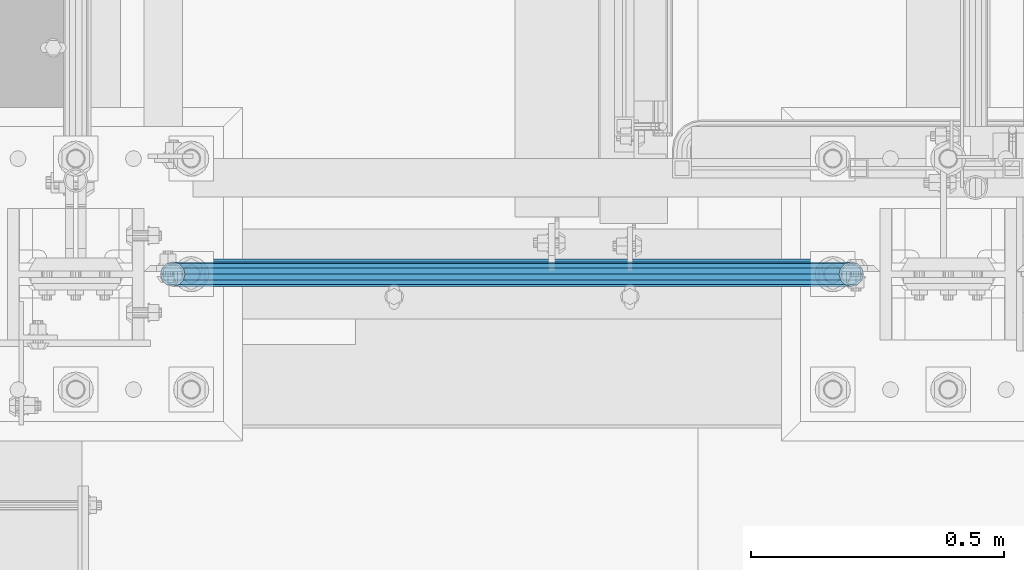
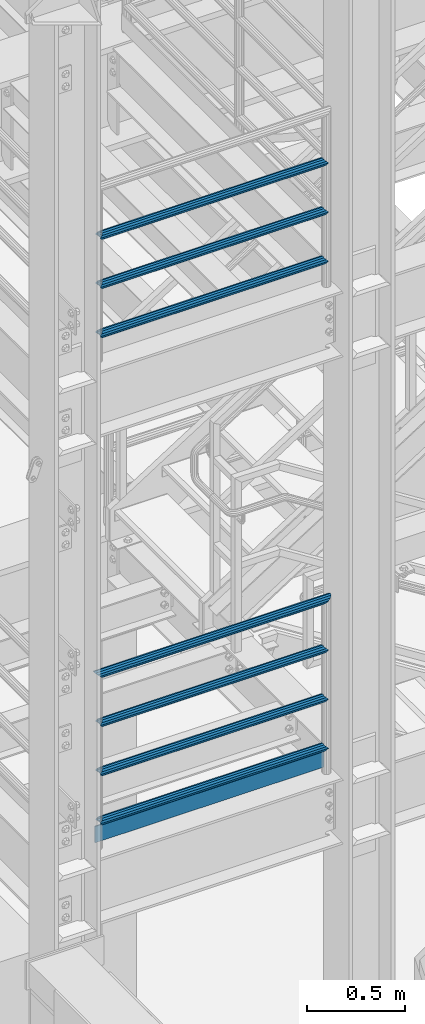
# One storey, part 930 of 1876: 8 beams, 2 elements without a shape of their own.
"""IFC2X3 building model written with IfcOpenShell, lengths in millimetres."""

from ifc_helpers import new_model, si_unit, frame, origin_with_axes, place, context, subcontext, project, spatial, faceted_brep, material, type_object, element, aggregate, save


model = new_model("IFC2X3")

# Units and contexts
model_context = context("Model", 3, precision=1e-05, world=origin_with_axes())
body_context = subcontext(model_context, "Body", "Model", "MODEL_VIEW")
ifc_project = project(units=[si_unit("LENGTHUNIT", "METRE", prefix="MILLI"), si_unit("AREAUNIT", "SQUARE_METRE"), si_unit("VOLUMEUNIT", "CUBIC_METRE"), si_unit("MASSUNIT", "GRAM", prefix="KILO"), si_unit("TIMEUNIT", "SECOND"), si_unit("PLANEANGLEUNIT", "RADIAN"), si_unit("SOLIDANGLEUNIT", "STERADIAN"), si_unit("THERMODYNAMICTEMPERATUREUNIT", "DEGREE_CELSIUS"), si_unit("LUMINOUSINTENSITYUNIT", "LUMEN")], contexts=[model_context])

# Site, building, storey
site_placement = place(None, origin_with_axes())
site = spatial("IfcSite", under=ifc_project, at=site_placement, CompositionType="ELEMENT")
building_placement = place(site_placement, origin_with_axes())
building = spatial("IfcBuilding", under=site, at=building_placement, Name="Undefined", CompositionType="ELEMENT")
storey_placement = place(building_placement, origin_with_axes())
storey = spatial("IfcBuildingStorey", under=building, at=storey_placement, Name="Undefined", CompositionType="ELEMENT", Elevation=0.0)

# Assembly, beams
assembly_1_placement = place(storey_placement, origin_with_axes())
assembly_1 = element("IfcElementAssembly", 1, at=assembly_1_placement, inside=storey, Name="RAIL", AssemblyPlace="NOTDEFINED", PredefinedType="RIGID_FRAME")
ifc_material_1 = material()
beam_type_1 = type_object("IfcBeamType", Name="PIPE1-1/2SCH40", PredefinedType="NOTDEFINED")
beam_1_placement = place(assembly_1_placement, frame((192.0875, -7112.0, 5292.72499999999), z_axis=(0.0, 0.0, 1.0), x_axis=(1.0, 0.0, 0.0)))
beam_1 = element("IfcBeam", 2, at=beam_1_placement, type_object=beam_type_1, material=ifc_material_1, Name="RAIL", ObjectType="PIPE1-1/2SCH40", context=body_context, shape_type="Brep", body=[
    faceted_brep([(1322.12780700668, -12.0649999999996, 20.8971929933186), (1322.12780700668, -12.0649999999996, 15.8661214311805), (1321.63437856882, -10.2235000000001, 17.7076214311801), (1318.895, 0.0, 20.4470000000001), (1318.895, 0.0, 24.1300000000001), (1321.63437856882, 10.2235000000001, 17.7076214311801), (1322.12780700668, 12.0649999999996, 15.8661214311805), (1322.12780700668, 12.0649999999996, 20.8971929933186), (1343.025, 24.1300000000001, 0.0), (1330.96, 20.8971929933186, 12.0649999999996), (1330.96, 20.8971929933186, -12.0649999999996), (1327.77042843786, 17.7076214311801, 10.2235000000001), (1330.50980700668, 20.4470000000001, 0.0), (1327.77042843786, 17.7076214311801, -10.2235000000001), (1322.12780700668, 12.0649999999996, -15.8661214311805), (1322.12780700668, 12.0649999999996, -20.8971929933186), (1321.63437856882, 10.2235000000001, -17.7076214311801), (1318.895, 0.0, -20.4470000000001), (1318.895, 0.0, -24.1300000000001), (1322.12780700668, -12.0649999999996, -15.8661214311805), (1322.12780700668, -12.0649999999996, -20.8971929933186), (1321.63437856882, -10.2235000000001, -17.7076214311801), (1343.025, -24.1300000000001, 0.0), (1330.96, -20.8971929933186, -12.0649999999996), (1330.96, -20.8971929933186, 12.0649999999996), (1327.77042843786, -17.7076214311801, -10.2235000000001), (1330.50980700668, -20.4470000000001, 0.0), (1327.77042843786, -17.7076214311801, 10.2235000000001), (12.0650000000064, -20.8971929933177, -12.0649999999987), (20.8971929933249, -12.0650000000005, -20.8971929933177), (0.0, 24.1299999999992, 0.0), (12.0650000000064, 20.8971929933177, -12.0649999999987), (12.0650000000064, 20.8971929933177, 12.0649999999987), (20.8971929933249, 12.0650000000005, 20.8971929933177), (24.1300000000064, 0.0, 24.130000000001), (20.8971929933249, 12.0650000000005, -20.8971929933177), (24.1300000000063, 0.0, -24.130000000001), (24.1300000000063, 0.0, -20.4470000000001), (20.8971929933249, -12.0650000000005, -15.8661214311796), (21.3906214311868, -10.2235000000001, -17.7076214311819), (21.3906214311868, 10.2235000000001, -17.7076214311819), (20.8971929933249, 12.0650000000005, -15.8661214311796), (15.2545715621445, 17.7076214311801, -10.2235000000001), (12.5151929933249, 20.4470000000001, 0.0), (15.2545715621445, 17.7076214311801, 10.2235000000001), (20.8971929933249, 12.0650000000005, 15.8661214311796), (21.3906214311868, 10.2235000000001, 17.7076214311819), (24.1300000000064, 0.0, 20.4470000000001), (21.3906214311868, -10.2235000000001, 17.7076214311819), (20.8971929933249, -12.0650000000005, 15.8661214311796), (20.8971929933249, -12.0650000000005, 20.8971929933177), (12.0650000000064, -20.8971929933177, 12.0649999999987), (0.0, -24.1299999999992, 0.0), (15.2545715621445, -17.7076214311801, 10.2235000000001), (12.5151929933249, -20.4470000000001, 0.0), (15.2545715621445, -17.7076214311801, -10.2235000000001)], [[[0, 1, 2, 3, 4]], [[4, 3, 5, 6, 7]], [[8, 9, 10]], [[7, 6, 11, 12, 13, 14, 15, 10, 9]], [[16, 17, 18, 15, 14]], [[19, 20, 18, 17, 21]], [[22, 23, 24]], [[24, 23, 20, 19, 25, 26, 27, 1, 0]], [[28, 29, 20, 23]], [[30, 31, 32]], [[33, 34, 4, 7]], [[32, 33, 7, 9]], [[30, 32, 9, 8]], [[31, 30, 8, 10]], [[35, 31, 10, 15]], [[36, 35, 15, 18]], [[29, 36, 18, 20]], [[37, 36, 29, 38, 39]], [[40, 41, 35, 36, 37]], [[32, 31, 35, 41, 42, 43, 44, 45, 33]], [[33, 45, 46, 47, 34]], [[34, 47, 48, 49, 50]], [[34, 50, 0, 4]], [[50, 51, 24, 0]], [[51, 52, 22, 24]], [[52, 28, 23, 22]], [[51, 28, 52]], [[50, 49, 53, 54, 55, 38, 29, 28, 51]], [[55, 54, 26, 25]], [[21, 39, 38, 55, 25, 19]], [[37, 39, 21, 17]], [[40, 37, 17, 16]], [[42, 41, 40, 16, 14, 13]], [[43, 42, 13, 12]], [[44, 43, 12, 11]], [[5, 46, 45, 44, 11, 6]], [[47, 46, 5, 3]], [[48, 47, 3, 2]], [[53, 49, 48, 2, 1, 27]], [[54, 53, 27, 26]]]),
])
beam_2_placement = place(assembly_1_placement, frame((1535.1125, -7112.0, 5597.52499999999), z_axis=(0.0, 0.0, -1.0), x_axis=(-1.0, 0.0, 0.0)))
beam_2 = element("IfcBeam", 3, at=beam_2_placement, type_object=beam_type_1, material=ifc_material_1, Name="RAIL", ObjectType="PIPE1-1/2SCH40", context=body_context, shape_type="Brep", body=[
    faceted_brep([(0.0, 24.1299999999992, 0.0), (12.0650000000064, 20.8971929933177, -12.0649999999987), (12.0650000000064, 20.8971929933177, 12.0649999999987), (12.0650000000064, -20.8971929933177, 12.0649999999987), (12.0650000000064, -20.8971929933177, -12.0649999999987), (0.0, -24.1299999999992, 0.0), (20.8971929933249, -12.0650000000005, 20.8971929933177), (20.8971929933249, -12.0650000000005, 15.8661214311796), (15.2545715621445, -17.7076214311801, 10.2235000000001), (12.5151929933249, -20.4470000000001, 0.0), (15.2545715621445, -17.7076214311801, -10.2235000000001), (20.8971929933249, -12.0650000000005, -15.8661214311796), (20.8971929933249, -12.0650000000005, -20.8971929933177), (24.1300000000063, 0.0, -20.4470000000001), (24.1300000000063, 0.0, -24.130000000001), (21.3906214311868, -10.2235000000001, -17.7076214311819), (21.3906214311868, 10.2235000000001, -17.7076214311819), (20.8971929933249, 12.0650000000005, -15.8661214311796), (20.8971929933249, 12.0650000000005, -20.8971929933177), (15.2545715621445, 17.7076214311801, -10.2235000000001), (12.5151929933249, 20.4470000000001, 0.0), (15.2545715621445, 17.7076214311801, 10.2235000000001), (20.8971929933249, 12.0650000000005, 15.8661214311796), (20.8971929933249, 12.0650000000005, 20.8971929933177), (21.3906214311868, 10.2235000000001, 17.7076214311819), (24.1300000000064, 0.0, 20.4470000000001), (24.1300000000064, 0.0, 24.130000000001), (21.3906214311868, -10.2235000000001, 17.7076214311819), (1343.025, 24.1300000000001, 0.0), (1330.96, 20.8971929933186, -12.0649999999996), (1322.12780700668, 12.0649999999996, -20.8971929933186), (1343.025, -24.1300000000001, 0.0), (1330.96, -20.8971929933186, -12.0649999999996), (1330.96, -20.8971929933186, 12.0649999999996), (1322.12780700668, -12.0649999999996, 20.8971929933186), (1322.12780700668, -12.0649999999996, -20.8971929933186), (1318.895, 0.0, -24.1300000000001), (1321.63437856882, 10.2235000000001, -17.7076214311801), (1318.895, 0.0, -20.4470000000001), (1322.12780700668, 12.0649999999996, -15.8661214311805), (1322.12780700668, -12.0649999999996, -15.8661214311805), (1321.63437856882, -10.2235000000001, -17.7076214311801), (1327.77042843786, -17.7076214311801, -10.2235000000001), (1330.50980700668, -20.4470000000001, 0.0), (1327.77042843786, -17.7076214311801, 10.2235000000001), (1322.12780700668, -12.0649999999996, 15.8661214311805), (1321.63437856882, -10.2235000000001, 17.7076214311801), (1318.895, 0.0, 20.4470000000001), (1318.895, 0.0, 24.1300000000001), (1322.12780700668, 12.0649999999996, 20.8971929933186), (1330.96, 20.8971929933186, 12.0649999999996), (1322.12780700668, 12.0649999999996, 15.8661214311805), (1327.77042843786, 17.7076214311801, 10.2235000000001), (1330.50980700668, 20.4470000000001, 0.0), (1327.77042843786, 17.7076214311801, -10.2235000000001), (1321.63437856882, 10.2235000000001, 17.7076214311801)], [[[0, 1, 2]], [[3, 4, 5]], [[6, 7, 8, 9, 10, 11, 12, 4, 3]], [[13, 14, 12, 11, 15]], [[16, 17, 18, 14, 13]], [[2, 1, 18, 17, 19, 20, 21, 22, 23]], [[23, 22, 24, 25, 26]], [[26, 25, 27, 7, 6]], [[1, 0, 28, 29]], [[18, 1, 29, 30]], [[31, 32, 33]], [[6, 3, 33, 34]], [[3, 5, 31, 33]], [[5, 4, 32, 31]], [[4, 12, 35, 32]], [[12, 14, 36, 35]], [[14, 18, 30, 36]], [[37, 38, 36, 30, 39]], [[40, 35, 36, 38, 41]], [[33, 32, 35, 40, 42, 43, 44, 45, 34]], [[34, 45, 46, 47, 48]], [[26, 6, 34, 48]], [[2, 23, 49, 50]], [[23, 26, 48, 49]], [[0, 2, 50, 28]], [[28, 50, 29]], [[49, 51, 52, 53, 54, 39, 30, 29, 50]], [[48, 47, 55, 51, 49]], [[25, 24, 55, 47]], [[55, 24, 22, 21, 52, 51]], [[21, 20, 53, 52]], [[20, 19, 54, 53]], [[19, 17, 16, 37, 39, 54]], [[16, 13, 38, 37]], [[13, 15, 41, 38]], [[41, 15, 11, 10, 42, 40]], [[10, 9, 43, 42]], [[9, 8, 44, 43]], [[8, 7, 27, 46, 45, 44]], [[27, 25, 47, 46]]]),
])
beam_3_placement = place(assembly_1_placement, frame((1535.1125, -7112.0, 5902.325), z_axis=(0.0, 0.0, -1.0), x_axis=(-1.0, 0.0, 0.0)))
beam_3 = element("IfcBeam", 4, at=beam_3_placement, type_object=beam_type_1, material=ifc_material_1, Name="RAIL", ObjectType="PIPE1-1/2SCH40", context=body_context, shape_type="Brep", body=[
    faceted_brep([(0.0, 24.1299999999992, 0.0), (12.0650000000064, 20.8971929933177, -12.0649999999987), (12.0650000000064, 20.8971929933177, 12.0649999999987), (12.0650000000064, -20.8971929933177, 12.0649999999987), (12.0650000000064, -20.8971929933177, -12.0649999999987), (0.0, -24.1299999999992, 0.0), (20.8971929933249, -12.0650000000005, 20.8971929933177), (20.8971929933249, -12.0650000000005, 15.8661214311796), (15.2545715621445, -17.7076214311801, 10.2235000000001), (12.5151929933249, -20.4470000000001, 0.0), (15.2545715621445, -17.7076214311801, -10.2235000000001), (20.8971929933249, -12.0650000000005, -15.8661214311796), (20.8971929933249, -12.0650000000005, -20.8971929933177), (24.1300000000063, 0.0, -20.4470000000001), (24.1300000000063, 0.0, -24.130000000001), (21.3906214311868, -10.2235000000001, -17.7076214311819), (21.3906214311868, 10.2235000000001, -17.7076214311819), (20.8971929933249, 12.0650000000005, -15.8661214311796), (20.8971929933249, 12.0650000000005, -20.8971929933177), (15.2545715621445, 17.7076214311801, -10.2235000000001), (12.5151929933249, 20.4470000000001, 0.0), (15.2545715621445, 17.7076214311801, 10.2235000000001), (20.8971929933249, 12.0650000000005, 15.8661214311796), (20.8971929933249, 12.0650000000005, 20.8971929933177), (21.3906214311868, 10.2235000000001, 17.7076214311819), (24.1300000000064, 0.0, 20.4470000000001), (24.1300000000064, 0.0, 24.130000000001), (21.3906214311868, -10.2235000000001, 17.7076214311819), (1343.025, 24.1300000000001, 0.0), (1330.96, 20.8971929933186, -12.0649999999996), (1322.12780700668, 12.0649999999996, -20.8971929933186), (1343.025, -24.1300000000001, 0.0), (1330.96, -20.8971929933186, -12.0649999999996), (1330.96, -20.8971929933186, 12.0649999999996), (1322.12780700668, -12.0649999999996, 20.8971929933186), (1322.12780700668, -12.0649999999996, -20.8971929933186), (1318.895, 0.0, -24.1300000000001), (1321.63437856882, 10.2235000000001, -17.7076214311801), (1318.895, 0.0, -20.4470000000001), (1322.12780700668, 12.0649999999996, -15.8661214311805), (1322.12780700668, -12.0649999999996, -15.8661214311805), (1321.63437856882, -10.2235000000001, -17.7076214311801), (1327.77042843786, -17.7076214311801, -10.2235000000001), (1330.50980700668, -20.4470000000001, 0.0), (1327.77042843786, -17.7076214311801, 10.2235000000001), (1322.12780700668, -12.0649999999996, 15.8661214311805), (1321.63437856882, -10.2235000000001, 17.7076214311801), (1318.895, 0.0, 20.4470000000001), (1318.895, 0.0, 24.1300000000001), (1322.12780700668, 12.0649999999996, 20.8971929933186), (1330.96, 20.8971929933186, 12.0649999999996), (1322.12780700668, 12.0649999999996, 15.8661214311805), (1327.77042843786, 17.7076214311801, 10.2235000000001), (1330.50980700668, 20.4470000000001, 0.0), (1327.77042843786, 17.7076214311801, -10.2235000000001), (1321.63437856882, 10.2235000000001, 17.7076214311801)], [[[0, 1, 2]], [[3, 4, 5]], [[6, 7, 8, 9, 10, 11, 12, 4, 3]], [[13, 14, 12, 11, 15]], [[16, 17, 18, 14, 13]], [[2, 1, 18, 17, 19, 20, 21, 22, 23]], [[23, 22, 24, 25, 26]], [[26, 25, 27, 7, 6]], [[1, 0, 28, 29]], [[18, 1, 29, 30]], [[31, 32, 33]], [[6, 3, 33, 34]], [[3, 5, 31, 33]], [[5, 4, 32, 31]], [[4, 12, 35, 32]], [[12, 14, 36, 35]], [[14, 18, 30, 36]], [[37, 38, 36, 30, 39]], [[40, 35, 36, 38, 41]], [[33, 32, 35, 40, 42, 43, 44, 45, 34]], [[34, 45, 46, 47, 48]], [[26, 6, 34, 48]], [[2, 23, 49, 50]], [[23, 26, 48, 49]], [[0, 2, 50, 28]], [[28, 50, 29]], [[49, 51, 52, 53, 54, 39, 30, 29, 50]], [[48, 47, 55, 51, 49]], [[25, 24, 55, 47]], [[55, 24, 22, 21, 52, 51]], [[21, 20, 53, 52]], [[20, 19, 54, 53]], [[19, 17, 16, 37, 39, 54]], [[16, 13, 38, 37]], [[13, 15, 41, 38]], [[41, 15, 11, 10, 42, 40]], [[10, 9, 43, 42]], [[9, 8, 44, 43]], [[8, 7, 27, 46, 45, 44]], [[27, 25, 47, 46]]]),
])
beam_4_placement = place(assembly_1_placement, frame((1559.2425, -7112.0, 6207.12499999999), z_axis=(0.0, 0.0, -1.0), x_axis=(-1.0, 0.0, 0.0)))
beam_4 = element("IfcBeam", 5, at=beam_4_placement, type_object=beam_type_1, material=ifc_material_1, Name="RAIL", ObjectType="PIPE1-1/2SCH40", context=body_context, shape_type="Brep", body=[
    faceted_brep([(24.1300000000001, -20.4469999999999, 0.0), (34.3535000000002, -17.7076214311803, 10.2235000000001), (1356.9315, -17.7076214311801, 10.2235000000001), (1367.155, -20.4470000000001, 0.0), (41.8376214311802, -10.2235000000001, 17.7076214311819), (1349.44737856882, -10.2235000000001, 17.7076214311801), (44.5770000000002, 0.0, 20.4470000000001), (1346.708, 0.0, 20.4470000000001), (41.8376214311802, 10.2235000000001, 17.7076214311819), (1349.44737856882, 10.2235000000001, 17.7076214311801), (34.3535000000002, 17.7076214311803, 10.2235000000001), (1356.9315, 17.7076214311801, 10.2235000000001), (24.1300000000001, 20.4469999999999, 0.0), (1367.155, 20.4470000000001, 0.0), (13.9065000000001, 17.7076214311803, -10.2235000000001), (1377.3785, 17.7076214311801, -10.2235000000001), (6.42237856882002, 10.2235000000001, -17.7076214311819), (1384.86262143118, 10.2235000000001, -17.7076214311801), (3.68299999999999, 0.0, -20.4470000000001), (1387.602, 0.0, -20.4470000000001), (6.42237856882002, -10.2235000000001, -17.7076214311819), (1384.86262143118, -10.2235000000001, -17.7076214311801), (13.9065000000001, -17.7076214311803, -10.2235000000001), (1377.3785, -17.7076214311801, -10.2235000000001), (24.1299999999854, -24.1299999999992, 0.0), (12.0650000000064, -20.8971929933177, -12.0649999999987), (1379.22, -20.8971929933186, -12.0649999999996), (1367.155, -24.1300000000001, 0.0), (3.23280700668147, -12.0650000000001, -20.8971929933177), (1388.05219299332, -12.0649999999996, -20.8971929933186), (-1.45519152283669e-11, 0.0, -24.130000000001), (1391.285, 0.0, -24.1300000000001), (3.23280700668147, 12.0650000000001, -20.8971929933177), (1388.05219299332, 12.0649999999996, -20.8971929933186), (12.0650000000064, 20.8971929933177, -12.0649999999987), (1379.22, 20.8971929933186, -12.0649999999996), (24.1300000000047, 24.1299999999992, 0.0), (1367.155, 24.1300000000001, 0.0), (36.1949999999997, 20.8971929933184, 12.0649999999987), (1355.09, 20.8971929933186, 12.0649999999996), (45.0271929933187, 12.0650000000001, 20.8971929933177), (1346.25780700668, 12.0649999999996, 20.8971929933186), (48.2600000000002, 0.0, 24.130000000001), (1343.025, 0.0, 24.1300000000001), (45.0271929933187, -12.0650000000001, 20.8971929933177), (1346.25780700668, -12.0649999999996, 20.8971929933186), (36.1949999999997, -20.8971929933184, 12.0649999999987), (1355.09, -20.8971929933186, 12.0649999999996)], [[[0, 1, 2, 3]], [[1, 4, 5, 2]], [[4, 6, 7, 5]], [[6, 8, 9, 7]], [[8, 10, 11, 9]], [[10, 12, 13, 11]], [[12, 14, 15, 13]], [[14, 16, 17, 15]], [[16, 18, 19, 17]], [[18, 20, 21, 19]], [[20, 22, 23, 21]], [[22, 0, 3, 23]], [[24, 25, 26, 27]], [[25, 28, 29, 26]], [[28, 30, 31, 29]], [[30, 32, 33, 31]], [[32, 34, 35, 33]], [[34, 36, 37, 35]], [[36, 38, 39, 37]], [[38, 40, 41, 39]], [[40, 42, 43, 41]], [[42, 44, 45, 43]], [[44, 46, 47, 45]], [[46, 24, 27, 47]], [[29, 31, 33, 35, 37, 39, 41, 43, 45, 47, 27, 26], [5, 7, 9, 11, 13, 15, 17, 19, 21, 23, 3, 2]], [[46, 44, 42, 40, 38, 36, 34, 32, 30, 28, 25, 24], [22, 20, 18, 16, 14, 12, 10, 8, 6, 4, 1, 0]]]),
])

assembly_2_placement = place(storey_placement, origin_with_axes())
assembly_2 = element("IfcElementAssembly", 6, at=assembly_2_placement, inside=storey, Name="RAIL", AssemblyPlace="NOTDEFINED", PredefinedType="RIGID_FRAME")
beam_5_placement = place(assembly_2_placement, frame((192.0875, -7112.0, 8315.325), z_axis=(0.0, 0.0, 1.0), x_axis=(1.0, 0.0, 0.0)))
beam_5 = element("IfcBeam", 7, at=beam_5_placement, type_object=beam_type_1, material=ifc_material_1, Name="RAIL", ObjectType="PIPE1-1/2SCH40", context=body_context, shape_type="Brep", body=[
    faceted_brep([(1322.12780700668, -12.0649999999996, 20.8971929933186), (1322.12780700668, -12.0649999999996, 15.8661214311805), (1321.63437856882, -10.2235000000001, 17.7076214311801), (1318.895, 0.0, 20.4470000000001), (1318.895, 0.0, 24.1300000000001), (1321.63437856882, 10.2235000000001, 17.7076214311801), (1322.12780700668, 12.0649999999996, 15.8661214311805), (1322.12780700668, 12.0649999999996, 20.8971929933186), (1343.025, 24.1300000000001, 0.0), (1330.96, 20.8971929933186, 12.0649999999996), (1330.96, 20.8971929933186, -12.0649999999996), (1327.77042843786, 17.7076214311801, 10.2235000000001), (1330.50980700668, 20.4470000000001, 0.0), (1327.77042843786, 17.7076214311801, -10.2235000000001), (1322.12780700668, 12.0649999999996, -15.8661214311805), (1322.12780700668, 12.0649999999996, -20.8971929933186), (1321.63437856882, 10.2235000000001, -17.7076214311801), (1318.895, 0.0, -20.4470000000001), (1318.895, 0.0, -24.1300000000001), (1322.12780700668, -12.0649999999996, -15.8661214311805), (1322.12780700668, -12.0649999999996, -20.8971929933186), (1321.63437856882, -10.2235000000001, -17.7076214311801), (1343.025, -24.1300000000001, 0.0), (1330.96, -20.8971929933186, -12.0649999999996), (1330.96, -20.8971929933186, 12.0649999999996), (1327.77042843786, -17.7076214311801, -10.2235000000001), (1330.50980700668, -20.4470000000001, 0.0), (1327.77042843786, -17.7076214311801, 10.2235000000001), (12.0650000000064, -20.8971929933177, -12.0649999999987), (20.8971929933249, -12.0650000000005, -20.8971929933177), (0.0, 24.1299999999992, 0.0), (12.0650000000064, 20.8971929933177, -12.0649999999987), (12.0650000000064, 20.8971929933177, 12.0649999999987), (20.8971929933249, 12.0650000000005, 20.8971929933177), (24.1300000000064, 0.0, 24.130000000001), (20.8971929933249, 12.0650000000005, -20.8971929933177), (24.1300000000063, 0.0, -24.130000000001), (24.1300000000063, 0.0, -20.4470000000001), (20.8971929933249, -12.0650000000005, -15.8661214311796), (21.3906214311868, -10.2235000000001, -17.7076214311819), (21.3906214311868, 10.2235000000001, -17.7076214311819), (20.8971929933249, 12.0650000000005, -15.8661214311796), (15.2545715621445, 17.7076214311801, -10.2235000000001), (12.5151929933249, 20.4470000000001, 0.0), (15.2545715621445, 17.7076214311801, 10.2235000000001), (20.8971929933249, 12.0650000000005, 15.8661214311796), (21.3906214311868, 10.2235000000001, 17.7076214311819), (24.1300000000064, 0.0, 20.4470000000001), (21.3906214311868, -10.2235000000001, 17.7076214311819), (20.8971929933249, -12.0650000000005, 15.8661214311796), (20.8971929933249, -12.0650000000005, 20.8971929933177), (12.0650000000064, -20.8971929933177, 12.0649999999987), (0.0, -24.1299999999992, 0.0), (15.2545715621445, -17.7076214311801, 10.2235000000001), (12.5151929933249, -20.4470000000001, 0.0), (15.2545715621445, -17.7076214311801, -10.2235000000001)], [[[0, 1, 2, 3, 4]], [[4, 3, 5, 6, 7]], [[8, 9, 10]], [[7, 6, 11, 12, 13, 14, 15, 10, 9]], [[16, 17, 18, 15, 14]], [[19, 20, 18, 17, 21]], [[22, 23, 24]], [[24, 23, 20, 19, 25, 26, 27, 1, 0]], [[28, 29, 20, 23]], [[30, 31, 32]], [[33, 34, 4, 7]], [[32, 33, 7, 9]], [[30, 32, 9, 8]], [[31, 30, 8, 10]], [[35, 31, 10, 15]], [[36, 35, 15, 18]], [[29, 36, 18, 20]], [[37, 36, 29, 38, 39]], [[40, 41, 35, 36, 37]], [[32, 31, 35, 41, 42, 43, 44, 45, 33]], [[33, 45, 46, 47, 34]], [[34, 47, 48, 49, 50]], [[34, 50, 0, 4]], [[50, 51, 24, 0]], [[51, 52, 22, 24]], [[52, 28, 23, 22]], [[51, 28, 52]], [[50, 49, 53, 54, 55, 38, 29, 28, 51]], [[55, 54, 26, 25]], [[21, 39, 38, 55, 25, 19]], [[37, 39, 21, 17]], [[40, 37, 17, 16]], [[42, 41, 40, 16, 14, 13]], [[43, 42, 13, 12]], [[44, 43, 12, 11]], [[5, 46, 45, 44, 11, 6]], [[47, 46, 5, 3]], [[48, 47, 3, 2]], [[53, 49, 48, 2, 1, 27]], [[54, 53, 27, 26]]]),
])
beam_6_placement = place(assembly_2_placement, frame((1535.1125, -7112.0, 8620.12499999999), z_axis=(0.0, 0.0, -1.0), x_axis=(-1.0, 0.0, 0.0)))
beam_6 = element("IfcBeam", 8, at=beam_6_placement, type_object=beam_type_1, material=ifc_material_1, Name="RAIL", ObjectType="PIPE1-1/2SCH40", context=body_context, shape_type="Brep", body=[
    faceted_brep([(0.0, 24.1299999999992, 0.0), (12.0650000000064, 20.8971929933177, -12.0649999999987), (12.0650000000064, 20.8971929933177, 12.0649999999987), (12.0650000000064, -20.8971929933177, 12.0649999999987), (12.0650000000064, -20.8971929933177, -12.0649999999987), (0.0, -24.1299999999992, 0.0), (20.8971929933249, -12.0650000000005, 20.8971929933177), (20.8971929933249, -12.0650000000005, 15.8661214311796), (15.2545715621445, -17.7076214311801, 10.2235000000001), (12.5151929933249, -20.4470000000001, 0.0), (15.2545715621445, -17.7076214311801, -10.2235000000001), (20.8971929933249, -12.0650000000005, -15.8661214311796), (20.8971929933249, -12.0650000000005, -20.8971929933177), (24.1300000000063, 0.0, -20.4470000000001), (24.1300000000063, 0.0, -24.130000000001), (21.3906214311868, -10.2235000000001, -17.7076214311819), (21.3906214311868, 10.2235000000001, -17.7076214311819), (20.8971929933249, 12.0650000000005, -15.8661214311796), (20.8971929933249, 12.0650000000005, -20.8971929933177), (15.2545715621445, 17.7076214311801, -10.2235000000001), (12.5151929933249, 20.4470000000001, 0.0), (15.2545715621445, 17.7076214311801, 10.2235000000001), (20.8971929933249, 12.0650000000005, 15.8661214311796), (20.8971929933249, 12.0650000000005, 20.8971929933177), (21.3906214311868, 10.2235000000001, 17.7076214311819), (24.1300000000064, 0.0, 20.4470000000001), (24.1300000000064, 0.0, 24.130000000001), (21.3906214311868, -10.2235000000001, 17.7076214311819), (1343.025, 24.1300000000001, 0.0), (1330.96, 20.8971929933186, -12.0649999999996), (1322.12780700668, 12.0649999999996, -20.8971929933186), (1343.025, -24.1300000000001, 0.0), (1330.96, -20.8971929933186, -12.0649999999996), (1330.96, -20.8971929933186, 12.0649999999996), (1322.12780700668, -12.0649999999996, 20.8971929933186), (1322.12780700668, -12.0649999999996, -20.8971929933186), (1318.895, 0.0, -24.1300000000001), (1321.63437856882, 10.2235000000001, -17.7076214311801), (1318.895, 0.0, -20.4470000000001), (1322.12780700668, 12.0649999999996, -15.8661214311805), (1322.12780700668, -12.0649999999996, -15.8661214311805), (1321.63437856882, -10.2235000000001, -17.7076214311801), (1327.77042843786, -17.7076214311801, -10.2235000000001), (1330.50980700668, -20.4470000000001, 0.0), (1327.77042843786, -17.7076214311801, 10.2235000000001), (1322.12780700668, -12.0649999999996, 15.8661214311805), (1321.63437856882, -10.2235000000001, 17.7076214311801), (1318.895, 0.0, 20.4470000000001), (1318.895, 0.0, 24.1300000000001), (1322.12780700668, 12.0649999999996, 20.8971929933186), (1330.96, 20.8971929933186, 12.0649999999996), (1322.12780700668, 12.0649999999996, 15.8661214311805), (1327.77042843786, 17.7076214311801, 10.2235000000001), (1330.50980700668, 20.4470000000001, 0.0), (1327.77042843786, 17.7076214311801, -10.2235000000001), (1321.63437856882, 10.2235000000001, 17.7076214311801)], [[[0, 1, 2]], [[3, 4, 5]], [[6, 7, 8, 9, 10, 11, 12, 4, 3]], [[13, 14, 12, 11, 15]], [[16, 17, 18, 14, 13]], [[2, 1, 18, 17, 19, 20, 21, 22, 23]], [[23, 22, 24, 25, 26]], [[26, 25, 27, 7, 6]], [[1, 0, 28, 29]], [[18, 1, 29, 30]], [[31, 32, 33]], [[6, 3, 33, 34]], [[3, 5, 31, 33]], [[5, 4, 32, 31]], [[4, 12, 35, 32]], [[12, 14, 36, 35]], [[14, 18, 30, 36]], [[37, 38, 36, 30, 39]], [[40, 35, 36, 38, 41]], [[33, 32, 35, 40, 42, 43, 44, 45, 34]], [[34, 45, 46, 47, 48]], [[26, 6, 34, 48]], [[2, 23, 49, 50]], [[23, 26, 48, 49]], [[0, 2, 50, 28]], [[28, 50, 29]], [[49, 51, 52, 53, 54, 39, 30, 29, 50]], [[48, 47, 55, 51, 49]], [[25, 24, 55, 47]], [[55, 24, 22, 21, 52, 51]], [[21, 20, 53, 52]], [[20, 19, 54, 53]], [[19, 17, 16, 37, 39, 54]], [[16, 13, 38, 37]], [[13, 15, 41, 38]], [[41, 15, 11, 10, 42, 40]], [[10, 9, 43, 42]], [[9, 8, 44, 43]], [[8, 7, 27, 46, 45, 44]], [[27, 25, 47, 46]]]),
])
beam_7_placement = place(assembly_2_placement, frame((1535.1125, -7112.0, 8924.925), z_axis=(0.0, 0.0, -1.0), x_axis=(-1.0, 0.0, 0.0)))
beam_7 = element("IfcBeam", 9, at=beam_7_placement, type_object=beam_type_1, material=ifc_material_1, Name="RAIL", ObjectType="PIPE1-1/2SCH40", context=body_context, shape_type="Brep", body=[
    faceted_brep([(0.0, 24.1299999999992, 0.0), (12.0650000000064, 20.8971929933177, -12.0649999999987), (12.0650000000064, 20.8971929933177, 12.0649999999987), (12.0650000000064, -20.8971929933177, 12.0649999999987), (12.0650000000064, -20.8971929933177, -12.0649999999987), (0.0, -24.1299999999992, 0.0), (20.8971929933249, -12.0650000000005, 20.8971929933177), (20.8971929933249, -12.0650000000005, 15.8661214311796), (15.2545715621445, -17.7076214311801, 10.2235000000001), (12.5151929933249, -20.4470000000001, 0.0), (15.2545715621445, -17.7076214311801, -10.2235000000001), (20.8971929933249, -12.0650000000005, -15.8661214311796), (20.8971929933249, -12.0650000000005, -20.8971929933177), (24.1300000000063, 0.0, -20.4470000000001), (24.1300000000063, 0.0, -24.130000000001), (21.3906214311868, -10.2235000000001, -17.7076214311819), (21.3906214311868, 10.2235000000001, -17.7076214311819), (20.8971929933249, 12.0650000000005, -15.8661214311796), (20.8971929933249, 12.0650000000005, -20.8971929933177), (15.2545715621445, 17.7076214311801, -10.2235000000001), (12.5151929933249, 20.4470000000001, 0.0), (15.2545715621445, 17.7076214311801, 10.2235000000001), (20.8971929933249, 12.0650000000005, 15.8661214311796), (20.8971929933249, 12.0650000000005, 20.8971929933177), (21.3906214311868, 10.2235000000001, 17.7076214311819), (24.1300000000064, 0.0, 20.4470000000001), (24.1300000000064, 0.0, 24.130000000001), (21.3906214311868, -10.2235000000001, 17.7076214311819), (1343.025, 24.1300000000001, 0.0), (1330.96, 20.8971929933186, -12.0649999999996), (1322.12780700668, 12.0649999999996, -20.8971929933186), (1343.025, -24.1300000000001, 0.0), (1330.96, -20.8971929933186, -12.0649999999996), (1330.96, -20.8971929933186, 12.0649999999996), (1322.12780700668, -12.0649999999996, 20.8971929933186), (1322.12780700668, -12.0649999999996, -20.8971929933186), (1318.895, 0.0, -24.1300000000001), (1321.63437856882, 10.2235000000001, -17.7076214311801), (1318.895, 0.0, -20.4470000000001), (1322.12780700668, 12.0649999999996, -15.8661214311805), (1322.12780700668, -12.0649999999996, -15.8661214311805), (1321.63437856882, -10.2235000000001, -17.7076214311801), (1327.77042843786, -17.7076214311801, -10.2235000000001), (1330.50980700668, -20.4470000000001, 0.0), (1327.77042843786, -17.7076214311801, 10.2235000000001), (1322.12780700668, -12.0649999999996, 15.8661214311805), (1321.63437856882, -10.2235000000001, 17.7076214311801), (1318.895, 0.0, 20.4470000000001), (1318.895, 0.0, 24.1300000000001), (1322.12780700668, 12.0649999999996, 20.8971929933186), (1330.96, 20.8971929933186, 12.0649999999996), (1322.12780700668, 12.0649999999996, 15.8661214311805), (1327.77042843786, 17.7076214311801, 10.2235000000001), (1330.50980700668, 20.4470000000001, 0.0), (1327.77042843786, 17.7076214311801, -10.2235000000001), (1321.63437856882, 10.2235000000001, 17.7076214311801)], [[[0, 1, 2]], [[3, 4, 5]], [[6, 7, 8, 9, 10, 11, 12, 4, 3]], [[13, 14, 12, 11, 15]], [[16, 17, 18, 14, 13]], [[2, 1, 18, 17, 19, 20, 21, 22, 23]], [[23, 22, 24, 25, 26]], [[26, 25, 27, 7, 6]], [[1, 0, 28, 29]], [[18, 1, 29, 30]], [[31, 32, 33]], [[6, 3, 33, 34]], [[3, 5, 31, 33]], [[5, 4, 32, 31]], [[4, 12, 35, 32]], [[12, 14, 36, 35]], [[14, 18, 30, 36]], [[37, 38, 36, 30, 39]], [[40, 35, 36, 38, 41]], [[33, 32, 35, 40, 42, 43, 44, 45, 34]], [[34, 45, 46, 47, 48]], [[26, 6, 34, 48]], [[2, 23, 49, 50]], [[23, 26, 48, 49]], [[0, 2, 50, 28]], [[28, 50, 29]], [[49, 51, 52, 53, 54, 39, 30, 29, 50]], [[48, 47, 55, 51, 49]], [[25, 24, 55, 47]], [[55, 24, 22, 21, 52, 51]], [[21, 20, 53, 52]], [[20, 19, 54, 53]], [[19, 17, 16, 37, 39, 54]], [[16, 13, 38, 37]], [[13, 15, 41, 38]], [[41, 15, 11, 10, 42, 40]], [[10, 9, 43, 42]], [[9, 8, 44, 43]], [[8, 7, 27, 46, 45, 44]], [[27, 25, 47, 46]]]),
])
aggregate(assembly_2, [beam_5, beam_6, beam_7])

# Beam
ifc_material_2 = material(Name="STEEL/A36")
beam_type_2 = type_object("IfcBeamType", PredefinedType="NOTDEFINED")
beam_8_placement = place(assembly_1_placement, frame((192.087499999998, -7085.0125, 5197.475), z_axis=(0.0, 0.0, 1.0), x_axis=(1.0, 0.0, 0.0)))
beam_8 = element("IfcBeam", 10, at=beam_8_placement, type_object=beam_type_2, material=ifc_material_2, Name="PLATE", context=body_context, shape_type="Brep", body=[
    faceted_brep([(0.0, 3.17500000000018, -50.8000000000002), (0.0, 3.17500000000018, 50.8000000000002), (1343.025, 3.17500000000018, 50.8000000000002), (1343.025, 3.17500000000018, -50.8000000000002), (0.0, -3.17500000000018, 50.8000000000002), (1343.025, -3.17500000000018, 50.8000000000002), (0.0, -3.17500000000018, -50.8000000000002), (1343.025, -3.17500000000018, -50.8000000000002)], [[[0, 1, 2, 3]], [[1, 4, 5, 2]], [[4, 6, 7, 5]], [[6, 0, 3, 7]], [[5, 7, 3, 2]], [[6, 4, 1, 0]]]),
])

aggregate(assembly_1, [beam_1, beam_2, beam_3, beam_4, beam_8])

save(model, "model.ifc")
